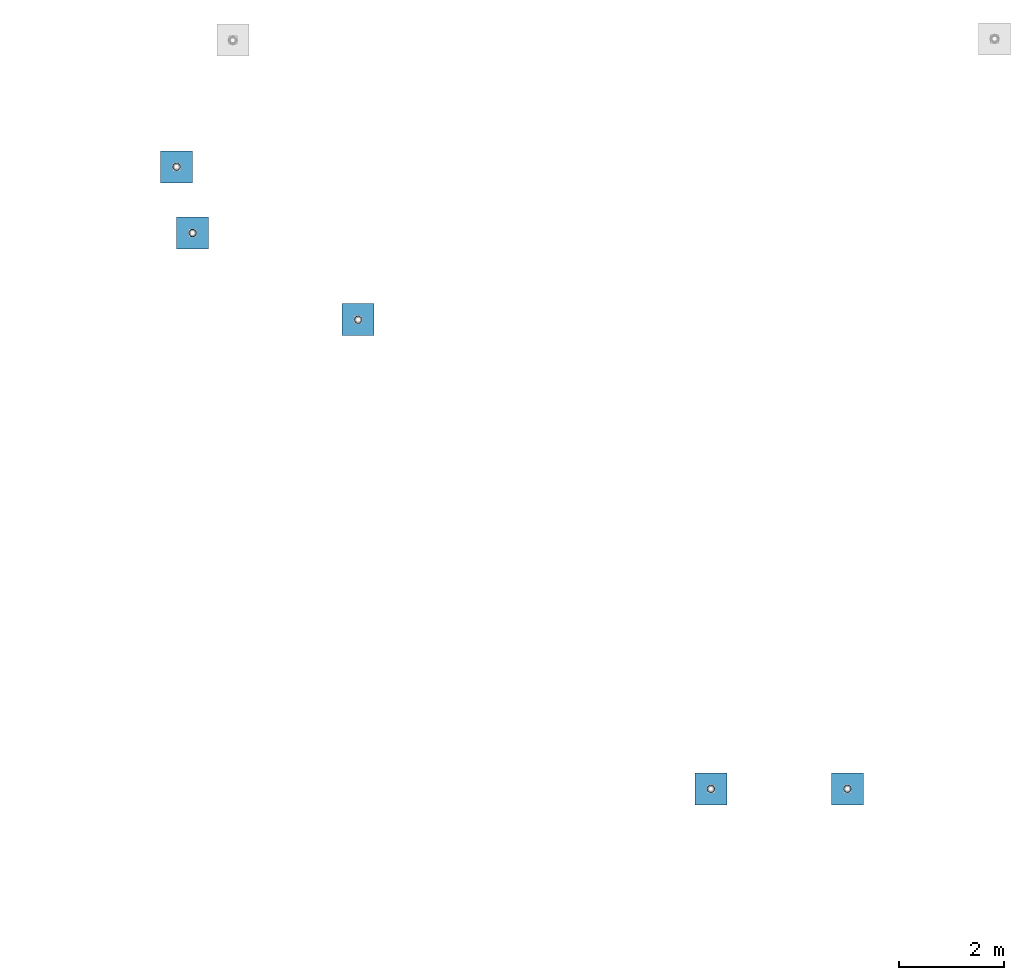
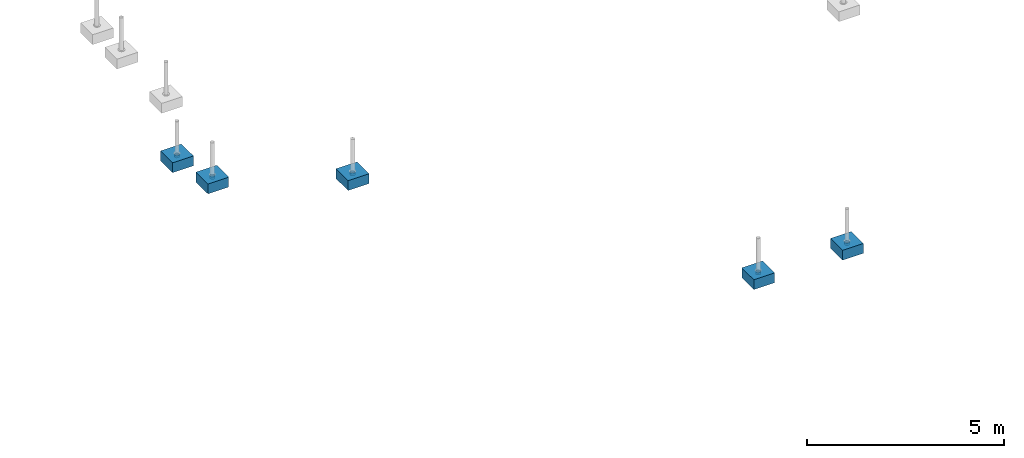
# One storey, part 1533 of 3843: 10 columns, 10 elements without a shape of their own.
"""IFC2X3 building model written with IfcOpenShell, lengths in millimetres."""

import ifcopenshell
import ifcopenshell.guid

model = None  # the IFC model being written
_history = None  # IfcOwnerHistory: only IFC2X3 demands one
_inside = {}  # id of a spatial element -> (the spatial element, [elements in it])
_under = {}  # id of a project, library or spatial element -> (it, [spatial elements below it])
_declared = {}  # id of a project -> (the project, [libraries it declares])
_typed = {}  # id of a type object -> (the type object, [elements of that type])
_made_of = {}  # id of a material, layer set ... -> (it, [elements and type objects made of it])


def new_model(schema):
    """Start an empty IFC model of exactly this schema.

    Asked for "IFC4X3", IfcOpenShell would pick the latest addendum, in which some entities
    have other attributes; the version numbers below select the first issue.
    IFC2X3 requires an IfcOwnerHistory on every rooted entity: one is made here for all.
    """
    global model, _history
    if schema == "IFC4X3":
        model = ifcopenshell.file(schema_version=(4, 3, 0, 0))
    else:
        model = ifcopenshell.file(schema=schema)
    _inside.clear()
    _under.clear()
    _declared.clear()
    _typed.clear()
    _made_of.clear()
    _history = None
    if model.schema == "IFC2X3":
        org = make("IfcOrganization", Name="unknown")
        user = make(
            "IfcPersonAndOrganization",
            ThePerson=make("IfcPerson", FamilyName="unknown"),
            TheOrganization=org,
        )
        app = make(
            "IfcApplication",
            ApplicationDeveloper=org,
            Version="unknown",
            ApplicationFullName="unknown",
            ApplicationIdentifier="unknown",
        )
        _history = make(
            "IfcOwnerHistory",
            OwningUser=user,
            OwningApplication=app,
            ChangeAction="ADDED",
            CreationDate=0,
        )
    return model


def make(cls, **values):
    """One entity of the class cls with the attributes given. An attribute that is None is left unset."""
    return model.create_entity(
        cls, **{name: value for name, value in values.items() if value is not None}
    )


def rooted(cls, **values):
    """An entity with a GlobalId (a new one), such as an element, a storey or a relation."""
    return make(cls, GlobalId=ifcopenshell.guid.new(), OwnerHistory=_history, **values)


def si_unit(unit_type, name, prefix=None):
    """IfcSIUnit, for example si_unit("LENGTHUNIT", "METRE", prefix="MILLI")."""
    return make("IfcSIUnit", UnitType=unit_type, Prefix=prefix, Name=name)


def assignment(units):
    """IfcUnitAssignment: the units of a project."""
    return None if units is None else make("IfcUnitAssignment", Units=units)


def point(xyz):
    """IfcCartesianPoint."""
    return None if xyz is None else make("IfcCartesianPoint", Coordinates=xyz)


def direction(xyz):
    """IfcDirection."""
    return None if xyz is None else make("IfcDirection", DirectionRatios=xyz)


def frame(location, z_axis=None, x_axis=None):
    """IfcAxis2Placement3D, a coordinate frame: its origin and axes. An axis left out is left unset."""
    return make(
        "IfcAxis2Placement3D",
        Location=point(location),
        Axis=direction(z_axis),
        RefDirection=direction(x_axis),
    )


def origin_with_axes():
    """The frame at (0, 0, 0) with the z axis (0, 0, 1) and the x axis (1, 0, 0) written out."""
    return frame((0.0, 0.0, 0.0), z_axis=(0.0, 0.0, 1.0), x_axis=(1.0, 0.0, 0.0))


def place(relative_to, where):
    """IfcLocalPlacement: puts the frame where relative to a parent placement (None: the world)."""
    return make(
        "IfcLocalPlacement", PlacementRelTo=relative_to, RelativePlacement=where
    )


def context(
    kind, dimensions, precision=None, world=None, true_north=None, identifier=None
):
    """IfcGeometricRepresentationContext, for example the 3D "Model" context."""
    return make(
        "IfcGeometricRepresentationContext",
        ContextIdentifier=identifier,
        ContextType=kind,
        CoordinateSpaceDimension=dimensions,
        Precision=precision,
        WorldCoordinateSystem=world,
        TrueNorth=true_north,
    )


def subcontext(parent, identifier, kind, view, scale=None):
    """IfcGeometricRepresentationSubContext, for example "Body" below "Model"."""
    return make(
        "IfcGeometricRepresentationSubContext",
        ContextIdentifier=identifier,
        ContextType=kind,
        ParentContext=parent,
        TargetScale=scale,
        TargetView=view,
    )


def project(units=None, contexts=None):
    """IfcProject with its units and contexts."""
    return rooted(
        "IfcProject",
        Name="project",
        RepresentationContexts=contexts,
        UnitsInContext=assignment(units),
    )


def spatial(cls, under=None, at=None, **own):
    """A site, building, storey or space (cls), placed at a placement, below another one or the project."""
    s = rooted(cls, ObjectPlacement=at, **own)
    if under is not None:
        _under.setdefault(under.id(), (under, []))[1].append(s)
    return s


def faces_of(points, faces, orient=None, outer=None):
    """IfcFace entities. A face is a list of loops; a loop is a list of indices into points, from 0.

    orient and outer hold one flag for each loop. By default every Orientation is true, the
    first loop of a face is its IfcFaceOuterBound and the others are IfcFaceBound.
    """
    made = []
    for i, loops in enumerate(faces):
        bounds = []
        for j, loop in enumerate(loops):
            is_outer = j == 0 if outer is None else outer[i][j]
            bounds.append(
                make(
                    "IfcFaceOuterBound" if is_outer else "IfcFaceBound",
                    Bound=make("IfcPolyLoop", Polygon=[points[k] for k in loop]),
                    Orientation=True if orient is None else orient[i][j],
                )
            )
        made.append(make("IfcFace", Bounds=bounds))
    return made


def faceted_brep(points, faces, orient=None, outer=None, voids=None):
    """IfcFacetedBrep: a solid bounded by flat faces; with voids (closed shells), ...WithVoids."""
    shared = [point(p) for p in points]
    hull = make("IfcClosedShell", CfsFaces=faces_of(shared, faces, orient, outer))
    if voids is None:
        return make("IfcFacetedBrep", Outer=hull)
    return make(
        "IfcFacetedBrepWithVoids",
        Outer=hull,
        Voids=[
            make(cls, CfsFaces=faces_of(shared, fs, o, b)) for cls, fs, o, b in voids
        ],
    )


def shape(context_of_items, identifier, shape_type, items):
    """IfcShapeRepresentation: the items that make up one representation, for example the "Body"."""
    return make(
        "IfcShapeRepresentation",
        ContextOfItems=context_of_items,
        RepresentationIdentifier=identifier,
        RepresentationType=shape_type,
        Items=items,
    )


def material(Name=None, Category=None):
    """IfcMaterial."""
    return make("IfcMaterial", Name=Name, Category=Category)


def made_of(thing, what):
    """Note that an element or type object is made of a material, layer set ...; save() writes the relation."""
    if what is not None:
        _made_of.setdefault(what.id(), (what, []))[1].append(thing)
    return thing


def type_object(cls, material=None, **own):
    """A type object (cls), such as IfcWallType, which elements share."""
    return made_of(rooted(cls, **own), material)


def element(
    cls,
    number,
    at=None,
    inside=None,
    cuts=None,
    type_object=None,
    material=None,
    context=None,
    identifier="Body",
    shape_type=None,
    held_by="IfcProductDefinitionShape",
    body=None,
    shapes=None,
    **own,
):
    """One element of the class cls, such as IfcWall. Its Tag is "e" and its number.

    at: its placement. inside: the storey or other place that contains it. cuts: it is an
    opening in that element (IfcRelVoidsElement). A single representation is given by context,
    identifier, shape_type and body (its items); several are given by shapes. held_by: the class
    of the entity that holds the representations. save() writes the other relations.
    """
    e = rooted(cls, Tag="e%d" % number, ObjectPlacement=at, **own)
    if body is not None:
        shapes = [shape(context, identifier, shape_type, body)]
    if shapes is not None:
        e.Representation = make(held_by, Representations=shapes)
    if inside is not None:
        _inside.setdefault(inside.id(), (inside, []))[1].append(e)
    if cuts is not None:
        rooted(
            "IfcRelVoidsElement", RelatingBuildingElement=cuts, RelatedOpeningElement=e
        )
    if type_object is not None:
        _typed.setdefault(type_object.id(), (type_object, []))[1].append(e)
    return made_of(e, material)


def aggregate(whole, parts):
    """IfcRelAggregates: a whole, such as a stair, and the parts it consists of."""
    return rooted("IfcRelAggregates", RelatingObject=whole, RelatedObjects=parts)


def save(model, path):
    """Write the relations noted so far, then the file.

    IfcRelAggregates (storeys below a building ...), IfcRelContainedInSpatialStructure (elements
    in a storey), IfcRelDefinesByType, IfcRelAssociatesMaterial and IfcRelDeclares: one each for
    every whole, place, type object, material and project.
    """
    for whole, parts in _under.values():
        aggregate(whole, parts)
    for where, things in _inside.values():
        rooted(
            "IfcRelContainedInSpatialStructure",
            RelatedElements=things,
            RelatingStructure=where,
        )
    for kind, things in _typed.values():
        rooted("IfcRelDefinesByType", RelatedObjects=things, RelatingType=kind)
    for what, things in _made_of.values():
        rooted("IfcRelAssociatesMaterial", RelatedObjects=things, RelatingMaterial=what)
    for by, libraries in _declared.values():
        rooted("IfcRelDeclares", RelatingContext=by, RelatedDefinitions=libraries)
    model.write(path)


model = new_model("IFC2X3")

# Units and contexts
model_context = context("Model", 3, precision=1e-05, world=origin_with_axes())
body_context = subcontext(model_context, "Body", "Model", "MODEL_VIEW")
ifc_project = project(units=[si_unit("LENGTHUNIT", "METRE", prefix="MILLI"), si_unit("AREAUNIT", "SQUARE_METRE"), si_unit("VOLUMEUNIT", "CUBIC_METRE"), si_unit("MASSUNIT", "GRAM", prefix="KILO"), si_unit("TIMEUNIT", "SECOND"), si_unit("PLANEANGLEUNIT", "RADIAN"), si_unit("SOLIDANGLEUNIT", "STERADIAN"), si_unit("THERMODYNAMICTEMPERATUREUNIT", "DEGREE_CELSIUS"), si_unit("LUMINOUSINTENSITYUNIT", "LUMEN")], contexts=[model_context])

# Site, building, storey
site_placement = place(None, origin_with_axes())
site = spatial("IfcSite", under=ifc_project, at=site_placement, CompositionType="ELEMENT")
building_placement = place(site_placement, origin_with_axes())
building = spatial("IfcBuilding", under=site, at=building_placement, Name="Undefined", CompositionType="ELEMENT")
storey_placement = place(building_placement, origin_with_axes())
storey = spatial("IfcBuildingStorey", under=building, at=storey_placement, Name="Undefined", CompositionType="ELEMENT", Elevation=0.0)

# Assembly, column
assembly_1_placement = place(storey_placement, origin_with_axes())
assembly_1 = element("IfcElementAssembly", 1, at=assembly_1_placement, inside=storey, Name="PLATE", AssemblyPlace="NOTDEFINED", PredefinedType="RIGID_FRAME")
ifc_material_1 = material()
column_type_1 = type_object("IfcColumnType", Name="PIPE5SCH40", PredefinedType="NOTDEFINED")
column_1_placement = place(assembly_1_placement, frame((-3692.61170980334, 71415.5314638615, 30378.4), z_axis=(-1.0, 0.0, 0.0), x_axis=(0.0, 0.0, 1.0)))
column_1 = element("IfcColumn", 2, at=column_1_placement, type_object=column_type_1, material=ifc_material_1, Name="PIPE_SLEEVE", ObjectType="PIPE5SCH40", context=body_context, shape_type="Brep", body=[
    faceted_brep([(0.0, -64.0587999999998, 0.0), (0.0, -60.9235391660477, 19.7952578392724), (76.2000000000007, -60.9235391660477, 19.7952578392724), (76.2000000000007, -64.0587999999998, 0.0), (0.0, -51.8246578392655, 37.6528179195593), (76.2000000000007, -51.8246578392655, 37.6528179195593), (0.0, -37.6528179195529, 51.8246578392718), (76.2000000000007, -37.6528179195529, 51.8246578392718), (0.0, -19.795257839266, 60.9235391660477), (76.2000000000007, -19.795257839266, 60.9235391660477), (0.0, 0.0, 64.0587999999989), (76.2000000000007, 0.0, 64.0587999999989), (0.0, 19.795257839266, 60.9235391660477), (76.2000000000007, 19.795257839266, 60.9235391660477), (0.0, 37.6528179195529, 51.8246578392718), (76.2000000000007, 37.6528179195529, 51.8246578392718), (0.0, 51.8246578392655, 37.6528179195593), (76.2000000000007, 51.8246578392655, 37.6528179195593), (0.0, 60.9235391660477, 19.7952578392724), (76.2000000000007, 60.9235391660477, 19.7952578392724), (0.0, 64.0587999999998, 0.0), (76.2000000000007, 64.0587999999998, 0.0), (0.0, 60.9235391660477, -19.7952578392724), (76.2000000000007, 60.9235391660477, -19.7952578392724), (0.0, 51.8246578392655, -37.6528179195593), (76.2000000000007, 51.8246578392655, -37.6528179195593), (0.0, 37.6528179195529, -51.8246578392718), (76.2000000000007, 37.6528179195529, -51.8246578392718), (0.0, 19.795257839266, -60.9235391660477), (76.2000000000007, 19.795257839266, -60.9235391660477), (0.0, 0.0, -64.0587999999989), (76.2000000000007, 0.0, -64.0587999999989), (0.0, -19.795257839266, -60.9235391660477), (76.2000000000007, -19.795257839266, -60.9235391660477), (0.0, -37.6528179195529, -51.8246578392718), (76.2000000000007, -37.6528179195529, -51.8246578392718), (0.0, -51.8246578392655, -37.6528179195593), (76.2000000000007, -51.8246578392655, -37.6528179195593), (0.0, -60.9235391660477, -19.7952578392724), (76.2000000000007, -60.9235391660477, -19.7952578392724), (0.0, -70.6120000000001, 0.0), (0.0, -67.1560027286332, -21.8203080068051), (76.2000000000007, -67.1560027286332, -21.8203080068051), (76.2000000000007, -70.6120000000001, 0.0), (0.0, -57.1263080068038, -41.5046922348702), (76.2000000000007, -57.1263080068038, -41.5046922348702), (0.0, -41.5046922348765, -57.126308006802), (76.2000000000007, -41.5046922348765, -57.126308006802), (0.0, -21.8203080068042, -67.1560027286323), (76.2000000000007, -21.8203080068042, -67.1560027286323), (0.0, 0.0, -70.6119999999937), (76.2000000000007, 0.0, -70.6119999999937), (0.0, 21.8203080068042, -67.1560027286323), (76.2000000000007, 21.8203080068042, -67.1560027286323), (0.0, 41.5046922348765, -57.126308006802), (76.2000000000007, 41.5046922348765, -57.126308006802), (0.0, 57.1263080068038, -41.5046922348702), (76.2000000000007, 57.1263080068038, -41.5046922348702), (0.0, 67.1560027286332, -21.8203080068051), (76.2000000000007, 67.1560027286332, -21.8203080068051), (0.0, 70.6120000000001, 0.0), (76.2000000000007, 70.6120000000001, 0.0), (0.0, 67.1560027286332, 21.8203080068051), (76.2000000000007, 67.1560027286332, 21.8203080068051), (0.0, 57.1263080068038, 41.5046922348702), (76.2000000000007, 57.1263080068038, 41.5046922348702), (0.0, 41.5046922348765, 57.126308006802), (76.2000000000007, 41.5046922348765, 57.126308006802), (0.0, 21.8203080068042, 67.1560027286323), (76.2000000000007, 21.8203080068042, 67.1560027286323), (0.0, 0.0, 70.6119999999937), (76.2000000000007, 0.0, 70.6119999999937), (0.0, -21.8203080068042, 67.1560027286323), (76.2000000000007, -21.8203080068042, 67.1560027286323), (0.0, -41.5046922348765, 57.126308006802), (76.2000000000007, -41.5046922348765, 57.126308006802), (0.0, -57.1263080068038, 41.5046922348702), (76.2000000000007, -57.1263080068038, 41.5046922348702), (0.0, -67.1560027286332, 21.8203080068051), (76.2000000000007, -67.1560027286332, 21.8203080068051)], [[[0, 1, 2, 3]], [[1, 4, 5, 2]], [[4, 6, 7, 5]], [[6, 8, 9, 7]], [[8, 10, 11, 9]], [[10, 12, 13, 11]], [[12, 14, 15, 13]], [[14, 16, 17, 15]], [[16, 18, 19, 17]], [[18, 20, 21, 19]], [[20, 22, 23, 21]], [[22, 24, 25, 23]], [[24, 26, 27, 25]], [[26, 28, 29, 27]], [[28, 30, 31, 29]], [[30, 32, 33, 31]], [[32, 34, 35, 33]], [[34, 36, 37, 35]], [[36, 38, 39, 37]], [[38, 0, 3, 39]], [[40, 41, 42, 43]], [[41, 44, 45, 42]], [[44, 46, 47, 45]], [[46, 48, 49, 47]], [[48, 50, 51, 49]], [[50, 52, 53, 51]], [[52, 54, 55, 53]], [[54, 56, 57, 55]], [[56, 58, 59, 57]], [[58, 60, 61, 59]], [[60, 62, 63, 61]], [[62, 64, 65, 63]], [[64, 66, 67, 65]], [[66, 68, 69, 67]], [[68, 70, 71, 69]], [[70, 72, 73, 71]], [[72, 74, 75, 73]], [[74, 76, 77, 75]], [[76, 78, 79, 77]], [[78, 40, 43, 79]], [[45, 47, 49, 51, 53, 55, 57, 59, 61, 63, 65, 67, 69, 71, 73, 75, 77, 79, 43, 42], [5, 7, 9, 11, 13, 15, 17, 19, 21, 23, 25, 27, 29, 31, 33, 35, 37, 39, 3, 2]], [[78, 76, 74, 72, 70, 68, 66, 64, 62, 60, 58, 56, 54, 52, 50, 48, 46, 44, 41, 40], [38, 36, 34, 32, 30, 28, 26, 24, 22, 20, 18, 16, 14, 12, 10, 8, 6, 4, 1, 0]]]),
])
aggregate(assembly_1, [column_1])

assembly_2_placement = place(storey_placement, origin_with_axes())
assembly_2 = element("IfcElementAssembly", 3, at=assembly_2_placement, inside=storey, Name="PLATE", AssemblyPlace="NOTDEFINED", PredefinedType="RIGID_FRAME")
column_2_placement = place(assembly_2_placement, frame((-6292.19438192249, 71414.9058535099, 30378.4), z_axis=(-1.0, 0.0, 0.0), x_axis=(0.0, 0.0, 1.0)))
column_2 = element("IfcColumn", 4, at=column_2_placement, type_object=column_type_1, material=ifc_material_1, Name="PIPE_SLEEVE", ObjectType="PIPE5SCH40", context=body_context, shape_type="Brep", body=[
    faceted_brep([(0.0, -64.0587999999998, 0.0), (0.0, -60.9235391660477, 19.7952578392724), (76.2000000000007, -60.9235391660477, 19.7952578392724), (76.2000000000007, -64.0587999999998, 0.0), (0.0, -51.8246578392655, 37.6528179195593), (76.2000000000007, -51.8246578392655, 37.6528179195593), (0.0, -37.6528179195529, 51.8246578392718), (76.2000000000007, -37.6528179195529, 51.8246578392718), (0.0, -19.795257839266, 60.9235391660477), (76.2000000000007, -19.795257839266, 60.9235391660477), (0.0, 0.0, 64.0587999999989), (76.2000000000007, 0.0, 64.0587999999989), (0.0, 19.795257839266, 60.9235391660477), (76.2000000000007, 19.795257839266, 60.9235391660477), (0.0, 37.6528179195529, 51.8246578392718), (76.2000000000007, 37.6528179195529, 51.8246578392718), (0.0, 51.8246578392655, 37.6528179195593), (76.2000000000007, 51.8246578392655, 37.6528179195593), (0.0, 60.9235391660477, 19.7952578392724), (76.2000000000007, 60.9235391660477, 19.7952578392724), (0.0, 64.0587999999998, 0.0), (76.2000000000007, 64.0587999999998, 0.0), (0.0, 60.9235391660477, -19.7952578392724), (76.2000000000007, 60.9235391660477, -19.7952578392724), (0.0, 51.8246578392655, -37.6528179195593), (76.2000000000007, 51.8246578392655, -37.6528179195593), (0.0, 37.6528179195529, -51.8246578392718), (76.2000000000007, 37.6528179195529, -51.8246578392718), (0.0, 19.795257839266, -60.9235391660477), (76.2000000000007, 19.795257839266, -60.9235391660477), (0.0, 0.0, -64.0587999999989), (76.2000000000007, 0.0, -64.0587999999989), (0.0, -19.795257839266, -60.9235391660477), (76.2000000000007, -19.795257839266, -60.9235391660477), (0.0, -37.6528179195529, -51.8246578392718), (76.2000000000007, -37.6528179195529, -51.8246578392718), (0.0, -51.8246578392655, -37.6528179195593), (76.2000000000007, -51.8246578392655, -37.6528179195593), (0.0, -60.9235391660477, -19.7952578392724), (76.2000000000007, -60.9235391660477, -19.7952578392724), (0.0, -70.6120000000001, 0.0), (0.0, -67.1560027286332, -21.8203080068051), (76.2000000000007, -67.1560027286332, -21.8203080068051), (76.2000000000007, -70.6120000000001, 0.0), (0.0, -57.1263080068038, -41.5046922348702), (76.2000000000007, -57.1263080068038, -41.5046922348702), (0.0, -41.5046922348765, -57.126308006802), (76.2000000000007, -41.5046922348765, -57.126308006802), (0.0, -21.8203080068042, -67.1560027286323), (76.2000000000007, -21.8203080068042, -67.1560027286323), (0.0, 0.0, -70.6119999999937), (76.2000000000007, 0.0, -70.6119999999937), (0.0, 21.8203080068042, -67.1560027286323), (76.2000000000007, 21.8203080068042, -67.1560027286323), (0.0, 41.5046922348765, -57.126308006802), (76.2000000000007, 41.5046922348765, -57.126308006802), (0.0, 57.1263080068038, -41.5046922348702), (76.2000000000007, 57.1263080068038, -41.5046922348702), (0.0, 67.1560027286332, -21.8203080068051), (76.2000000000007, 67.1560027286332, -21.8203080068051), (0.0, 70.6120000000001, 0.0), (76.2000000000007, 70.6120000000001, 0.0), (0.0, 67.1560027286332, 21.8203080068051), (76.2000000000007, 67.1560027286332, 21.8203080068051), (0.0, 57.1263080068038, 41.5046922348702), (76.2000000000007, 57.1263080068038, 41.5046922348702), (0.0, 41.5046922348765, 57.126308006802), (76.2000000000007, 41.5046922348765, 57.126308006802), (0.0, 21.8203080068042, 67.1560027286323), (76.2000000000007, 21.8203080068042, 67.1560027286323), (0.0, 0.0, 70.6119999999937), (76.2000000000007, 0.0, 70.6119999999937), (0.0, -21.8203080068042, 67.1560027286323), (76.2000000000007, -21.8203080068042, 67.1560027286323), (0.0, -41.5046922348765, 57.126308006802), (76.2000000000007, -41.5046922348765, 57.126308006802), (0.0, -57.1263080068038, 41.5046922348702), (76.2000000000007, -57.1263080068038, 41.5046922348702), (0.0, -67.1560027286332, 21.8203080068051), (76.2000000000007, -67.1560027286332, 21.8203080068051)], [[[0, 1, 2, 3]], [[1, 4, 5, 2]], [[4, 6, 7, 5]], [[6, 8, 9, 7]], [[8, 10, 11, 9]], [[10, 12, 13, 11]], [[12, 14, 15, 13]], [[14, 16, 17, 15]], [[16, 18, 19, 17]], [[18, 20, 21, 19]], [[20, 22, 23, 21]], [[22, 24, 25, 23]], [[24, 26, 27, 25]], [[26, 28, 29, 27]], [[28, 30, 31, 29]], [[30, 32, 33, 31]], [[32, 34, 35, 33]], [[34, 36, 37, 35]], [[36, 38, 39, 37]], [[38, 0, 3, 39]], [[40, 41, 42, 43]], [[41, 44, 45, 42]], [[44, 46, 47, 45]], [[46, 48, 49, 47]], [[48, 50, 51, 49]], [[50, 52, 53, 51]], [[52, 54, 55, 53]], [[54, 56, 57, 55]], [[56, 58, 59, 57]], [[58, 60, 61, 59]], [[60, 62, 63, 61]], [[62, 64, 65, 63]], [[64, 66, 67, 65]], [[66, 68, 69, 67]], [[68, 70, 71, 69]], [[70, 72, 73, 71]], [[72, 74, 75, 73]], [[74, 76, 77, 75]], [[76, 78, 79, 77]], [[78, 40, 43, 79]], [[45, 47, 49, 51, 53, 55, 57, 59, 61, 63, 65, 67, 69, 71, 73, 75, 77, 79, 43, 42], [5, 7, 9, 11, 13, 15, 17, 19, 21, 23, 25, 27, 29, 31, 33, 35, 37, 39, 3, 2]], [[78, 76, 74, 72, 70, 68, 66, 64, 62, 60, 58, 56, 54, 52, 50, 48, 46, 44, 41, 40], [38, 36, 34, 32, 30, 28, 26, 24, 22, 20, 18, 16, 14, 12, 10, 8, 6, 4, 1, 0]]]),
])
aggregate(assembly_2, [column_2])

assembly_3_placement = place(storey_placement, origin_with_axes())
assembly_3 = element("IfcElementAssembly", 5, at=assembly_3_placement, inside=storey, Name="PLATE", AssemblyPlace="NOTDEFINED", PredefinedType="RIGID_FRAME")
column_3_placement = place(assembly_3_placement, frame((-13009.9315797985, 80350.2009584904, 30378.4), z_axis=(-1.0, 0.0, 0.0), x_axis=(0.0, 0.0, 1.0)))
column_3 = element("IfcColumn", 6, at=column_3_placement, type_object=column_type_1, material=ifc_material_1, Name="PIPE_SLEEVE", ObjectType="PIPE5SCH40", context=body_context, shape_type="Brep", body=[
    faceted_brep([(0.0, -64.0587999999998, 0.0), (0.0, -60.9235391660477, 19.7952578392724), (76.2000000000007, -60.9235391660477, 19.7952578392724), (76.2000000000007, -64.0587999999998, 0.0), (0.0, -51.8246578392655, 37.6528179195593), (76.2000000000007, -51.8246578392655, 37.6528179195593), (0.0, -37.6528179195529, 51.8246578392718), (76.2000000000007, -37.6528179195529, 51.8246578392718), (0.0, -19.795257839266, 60.9235391660477), (76.2000000000007, -19.795257839266, 60.9235391660477), (0.0, 0.0, 64.0587999999989), (76.2000000000007, 0.0, 64.0587999999989), (0.0, 19.795257839266, 60.9235391660477), (76.2000000000007, 19.795257839266, 60.9235391660477), (0.0, 37.6528179195529, 51.8246578392718), (76.2000000000007, 37.6528179195529, 51.8246578392718), (0.0, 51.8246578392655, 37.6528179195593), (76.2000000000007, 51.8246578392655, 37.6528179195593), (0.0, 60.9235391660477, 19.7952578392724), (76.2000000000007, 60.9235391660477, 19.7952578392724), (0.0, 64.0587999999998, 0.0), (76.2000000000007, 64.0587999999998, 0.0), (0.0, 60.9235391660477, -19.7952578392724), (76.2000000000007, 60.9235391660477, -19.7952578392724), (0.0, 51.8246578392655, -37.6528179195593), (76.2000000000007, 51.8246578392655, -37.6528179195593), (0.0, 37.6528179195529, -51.8246578392718), (76.2000000000007, 37.6528179195529, -51.8246578392718), (0.0, 19.795257839266, -60.9235391660477), (76.2000000000007, 19.795257839266, -60.9235391660477), (0.0, 0.0, -64.0587999999989), (76.2000000000007, 0.0, -64.0587999999989), (0.0, -19.795257839266, -60.9235391660477), (76.2000000000007, -19.795257839266, -60.9235391660477), (0.0, -37.6528179195529, -51.8246578392718), (76.2000000000007, -37.6528179195529, -51.8246578392718), (0.0, -51.8246578392655, -37.6528179195593), (76.2000000000007, -51.8246578392655, -37.6528179195593), (0.0, -60.9235391660477, -19.7952578392724), (76.2000000000007, -60.9235391660477, -19.7952578392724), (0.0, -70.6120000000001, 0.0), (0.0, -67.1560027286332, -21.8203080068051), (76.2000000000007, -67.1560027286332, -21.8203080068051), (76.2000000000007, -70.6120000000001, 0.0), (0.0, -57.1263080068038, -41.5046922348702), (76.2000000000007, -57.1263080068038, -41.5046922348702), (0.0, -41.5046922348765, -57.126308006802), (76.2000000000007, -41.5046922348765, -57.126308006802), (0.0, -21.8203080068042, -67.1560027286323), (76.2000000000007, -21.8203080068042, -67.1560027286323), (0.0, 0.0, -70.6119999999937), (76.2000000000007, 0.0, -70.6119999999937), (0.0, 21.8203080068042, -67.1560027286323), (76.2000000000007, 21.8203080068042, -67.1560027286323), (0.0, 41.5046922348765, -57.126308006802), (76.2000000000007, 41.5046922348765, -57.126308006802), (0.0, 57.1263080068038, -41.5046922348702), (76.2000000000007, 57.1263080068038, -41.5046922348702), (0.0, 67.1560027286332, -21.8203080068051), (76.2000000000007, 67.1560027286332, -21.8203080068051), (0.0, 70.6120000000001, 0.0), (76.2000000000007, 70.6120000000001, 0.0), (0.0, 67.1560027286332, 21.8203080068051), (76.2000000000007, 67.1560027286332, 21.8203080068051), (0.0, 57.1263080068038, 41.5046922348702), (76.2000000000007, 57.1263080068038, 41.5046922348702), (0.0, 41.5046922348765, 57.126308006802), (76.2000000000007, 41.5046922348765, 57.126308006802), (0.0, 21.8203080068042, 67.1560027286323), (76.2000000000007, 21.8203080068042, 67.1560027286323), (0.0, 0.0, 70.6119999999937), (76.2000000000007, 0.0, 70.6119999999937), (0.0, -21.8203080068042, 67.1560027286323), (76.2000000000007, -21.8203080068042, 67.1560027286323), (0.0, -41.5046922348765, 57.126308006802), (76.2000000000007, -41.5046922348765, 57.126308006802), (0.0, -57.1263080068038, 41.5046922348702), (76.2000000000007, -57.1263080068038, 41.5046922348702), (0.0, -67.1560027286332, 21.8203080068051), (76.2000000000007, -67.1560027286332, 21.8203080068051)], [[[0, 1, 2, 3]], [[1, 4, 5, 2]], [[4, 6, 7, 5]], [[6, 8, 9, 7]], [[8, 10, 11, 9]], [[10, 12, 13, 11]], [[12, 14, 15, 13]], [[14, 16, 17, 15]], [[16, 18, 19, 17]], [[18, 20, 21, 19]], [[20, 22, 23, 21]], [[22, 24, 25, 23]], [[24, 26, 27, 25]], [[26, 28, 29, 27]], [[28, 30, 31, 29]], [[30, 32, 33, 31]], [[32, 34, 35, 33]], [[34, 36, 37, 35]], [[36, 38, 39, 37]], [[38, 0, 3, 39]], [[40, 41, 42, 43]], [[41, 44, 45, 42]], [[44, 46, 47, 45]], [[46, 48, 49, 47]], [[48, 50, 51, 49]], [[50, 52, 53, 51]], [[52, 54, 55, 53]], [[54, 56, 57, 55]], [[56, 58, 59, 57]], [[58, 60, 61, 59]], [[60, 62, 63, 61]], [[62, 64, 65, 63]], [[64, 66, 67, 65]], [[66, 68, 69, 67]], [[68, 70, 71, 69]], [[70, 72, 73, 71]], [[72, 74, 75, 73]], [[74, 76, 77, 75]], [[76, 78, 79, 77]], [[78, 40, 43, 79]], [[45, 47, 49, 51, 53, 55, 57, 59, 61, 63, 65, 67, 69, 71, 73, 75, 77, 79, 43, 42], [5, 7, 9, 11, 13, 15, 17, 19, 21, 23, 25, 27, 29, 31, 33, 35, 37, 39, 3, 2]], [[78, 76, 74, 72, 70, 68, 66, 64, 62, 60, 58, 56, 54, 52, 50, 48, 46, 44, 41, 40], [38, 36, 34, 32, 30, 28, 26, 24, 22, 20, 18, 16, 14, 12, 10, 8, 6, 4, 1, 0]]]),
])
aggregate(assembly_3, [column_3])

assembly_4_placement = place(storey_placement, origin_with_axes())
assembly_4 = element("IfcElementAssembly", 7, at=assembly_4_placement, inside=storey, Name="PLATE", AssemblyPlace="NOTDEFINED", PredefinedType="RIGID_FRAME")
column_4_placement = place(assembly_4_placement, frame((-16161.9587099254, 81999.8381807804, 30378.4), z_axis=(-1.0, 0.0, 0.0), x_axis=(0.0, 0.0, 1.0)))
column_4 = element("IfcColumn", 8, at=column_4_placement, type_object=column_type_1, material=ifc_material_1, Name="PIPE_SLEEVE", ObjectType="PIPE5SCH40", context=body_context, shape_type="Brep", body=[
    faceted_brep([(0.0, -64.0587999999998, 0.0), (0.0, -60.9235391660477, 19.7952578392724), (76.2000000000007, -60.9235391660477, 19.7952578392724), (76.2000000000007, -64.0587999999998, 0.0), (0.0, -51.8246578392655, 37.6528179195593), (76.2000000000007, -51.8246578392655, 37.6528179195593), (0.0, -37.6528179195529, 51.8246578392718), (76.2000000000007, -37.6528179195529, 51.8246578392718), (0.0, -19.795257839266, 60.9235391660477), (76.2000000000007, -19.795257839266, 60.9235391660477), (0.0, 0.0, 64.0587999999989), (76.2000000000007, 0.0, 64.0587999999989), (0.0, 19.795257839266, 60.9235391660477), (76.2000000000007, 19.795257839266, 60.9235391660477), (0.0, 37.6528179195529, 51.8246578392718), (76.2000000000007, 37.6528179195529, 51.8246578392718), (0.0, 51.8246578392655, 37.6528179195593), (76.2000000000007, 51.8246578392655, 37.6528179195593), (0.0, 60.9235391660477, 19.7952578392724), (76.2000000000007, 60.9235391660477, 19.7952578392724), (0.0, 64.0587999999998, 0.0), (76.2000000000007, 64.0587999999998, 0.0), (0.0, 60.9235391660477, -19.7952578392724), (76.2000000000007, 60.9235391660477, -19.7952578392724), (0.0, 51.8246578392655, -37.6528179195593), (76.2000000000007, 51.8246578392655, -37.6528179195593), (0.0, 37.6528179195529, -51.8246578392718), (76.2000000000007, 37.6528179195529, -51.8246578392718), (0.0, 19.795257839266, -60.9235391660477), (76.2000000000007, 19.795257839266, -60.9235391660477), (0.0, 0.0, -64.0587999999989), (76.2000000000007, 0.0, -64.0587999999989), (0.0, -19.795257839266, -60.9235391660477), (76.2000000000007, -19.795257839266, -60.9235391660477), (0.0, -37.6528179195529, -51.8246578392718), (76.2000000000007, -37.6528179195529, -51.8246578392718), (0.0, -51.8246578392655, -37.6528179195593), (76.2000000000007, -51.8246578392655, -37.6528179195593), (0.0, -60.9235391660477, -19.7952578392724), (76.2000000000007, -60.9235391660477, -19.7952578392724), (0.0, -70.6120000000001, 0.0), (0.0, -67.1560027286332, -21.8203080068051), (76.2000000000007, -67.1560027286332, -21.8203080068051), (76.2000000000007, -70.6120000000001, 0.0), (0.0, -57.1263080068038, -41.5046922348702), (76.2000000000007, -57.1263080068038, -41.5046922348702), (0.0, -41.5046922348765, -57.126308006802), (76.2000000000007, -41.5046922348765, -57.126308006802), (0.0, -21.8203080068042, -67.1560027286323), (76.2000000000007, -21.8203080068042, -67.1560027286323), (0.0, 0.0, -70.6119999999937), (76.2000000000007, 0.0, -70.6119999999937), (0.0, 21.8203080068042, -67.1560027286323), (76.2000000000007, 21.8203080068042, -67.1560027286323), (0.0, 41.5046922348765, -57.126308006802), (76.2000000000007, 41.5046922348765, -57.126308006802), (0.0, 57.1263080068038, -41.5046922348702), (76.2000000000007, 57.1263080068038, -41.5046922348702), (0.0, 67.1560027286332, -21.8203080068051), (76.2000000000007, 67.1560027286332, -21.8203080068051), (0.0, 70.6120000000001, 0.0), (76.2000000000007, 70.6120000000001, 0.0), (0.0, 67.1560027286332, 21.8203080068051), (76.2000000000007, 67.1560027286332, 21.8203080068051), (0.0, 57.1263080068038, 41.5046922348702), (76.2000000000007, 57.1263080068038, 41.5046922348702), (0.0, 41.5046922348765, 57.126308006802), (76.2000000000007, 41.5046922348765, 57.126308006802), (0.0, 21.8203080068042, 67.1560027286323), (76.2000000000007, 21.8203080068042, 67.1560027286323), (0.0, 0.0, 70.6119999999937), (76.2000000000007, 0.0, 70.6119999999937), (0.0, -21.8203080068042, 67.1560027286323), (76.2000000000007, -21.8203080068042, 67.1560027286323), (0.0, -41.5046922348765, 57.126308006802), (76.2000000000007, -41.5046922348765, 57.126308006802), (0.0, -57.1263080068038, 41.5046922348702), (76.2000000000007, -57.1263080068038, 41.5046922348702), (0.0, -67.1560027286332, 21.8203080068051), (76.2000000000007, -67.1560027286332, 21.8203080068051)], [[[0, 1, 2, 3]], [[1, 4, 5, 2]], [[4, 6, 7, 5]], [[6, 8, 9, 7]], [[8, 10, 11, 9]], [[10, 12, 13, 11]], [[12, 14, 15, 13]], [[14, 16, 17, 15]], [[16, 18, 19, 17]], [[18, 20, 21, 19]], [[20, 22, 23, 21]], [[22, 24, 25, 23]], [[24, 26, 27, 25]], [[26, 28, 29, 27]], [[28, 30, 31, 29]], [[30, 32, 33, 31]], [[32, 34, 35, 33]], [[34, 36, 37, 35]], [[36, 38, 39, 37]], [[38, 0, 3, 39]], [[40, 41, 42, 43]], [[41, 44, 45, 42]], [[44, 46, 47, 45]], [[46, 48, 49, 47]], [[48, 50, 51, 49]], [[50, 52, 53, 51]], [[52, 54, 55, 53]], [[54, 56, 57, 55]], [[56, 58, 59, 57]], [[58, 60, 61, 59]], [[60, 62, 63, 61]], [[62, 64, 65, 63]], [[64, 66, 67, 65]], [[66, 68, 69, 67]], [[68, 70, 71, 69]], [[70, 72, 73, 71]], [[72, 74, 75, 73]], [[74, 76, 77, 75]], [[76, 78, 79, 77]], [[78, 40, 43, 79]], [[45, 47, 49, 51, 53, 55, 57, 59, 61, 63, 65, 67, 69, 71, 73, 75, 77, 79, 43, 42], [5, 7, 9, 11, 13, 15, 17, 19, 21, 23, 25, 27, 29, 31, 33, 35, 37, 39, 3, 2]], [[78, 76, 74, 72, 70, 68, 66, 64, 62, 60, 58, 56, 54, 52, 50, 48, 46, 44, 41, 40], [38, 36, 34, 32, 30, 28, 26, 24, 22, 20, 18, 16, 14, 12, 10, 8, 6, 4, 1, 0]]]),
])
aggregate(assembly_4, [column_4])

assembly_5_placement = place(storey_placement, origin_with_axes())
assembly_5 = element("IfcElementAssembly", 9, at=assembly_5_placement, inside=storey, Name="PLATE", AssemblyPlace="NOTDEFINED", PredefinedType="RIGID_FRAME")
column_5_placement = place(assembly_5_placement, frame((-16467.6075136364, 83260.6490328312, 30378.4), z_axis=(-1.0, 0.0, 0.0), x_axis=(0.0, 0.0, 1.0)))
column_5 = element("IfcColumn", 10, at=column_5_placement, type_object=column_type_1, material=ifc_material_1, Name="PIPE_SLEEVE", ObjectType="PIPE5SCH40", context=body_context, shape_type="Brep", body=[
    faceted_brep([(0.0, -64.0587999999998, 0.0), (0.0, -60.9235391660477, 19.7952578392724), (76.2000000000007, -60.9235391660477, 19.7952578392724), (76.2000000000007, -64.0587999999998, 0.0), (0.0, -51.8246578392655, 37.6528179195593), (76.2000000000007, -51.8246578392655, 37.6528179195593), (0.0, -37.6528179195529, 51.8246578392718), (76.2000000000007, -37.6528179195529, 51.8246578392718), (0.0, -19.795257839266, 60.9235391660477), (76.2000000000007, -19.795257839266, 60.9235391660477), (0.0, 0.0, 64.0587999999989), (76.2000000000007, 0.0, 64.0587999999989), (0.0, 19.795257839266, 60.9235391660477), (76.2000000000007, 19.795257839266, 60.9235391660477), (0.0, 37.6528179195529, 51.8246578392718), (76.2000000000007, 37.6528179195529, 51.8246578392718), (0.0, 51.8246578392655, 37.6528179195593), (76.2000000000007, 51.8246578392655, 37.6528179195593), (0.0, 60.9235391660477, 19.7952578392724), (76.2000000000007, 60.9235391660477, 19.7952578392724), (0.0, 64.0587999999998, 0.0), (76.2000000000007, 64.0587999999998, 0.0), (0.0, 60.9235391660477, -19.7952578392724), (76.2000000000007, 60.9235391660477, -19.7952578392724), (0.0, 51.8246578392655, -37.6528179195593), (76.2000000000007, 51.8246578392655, -37.6528179195593), (0.0, 37.6528179195529, -51.8246578392718), (76.2000000000007, 37.6528179195529, -51.8246578392718), (0.0, 19.795257839266, -60.9235391660477), (76.2000000000007, 19.795257839266, -60.9235391660477), (0.0, 0.0, -64.0587999999989), (76.2000000000007, 0.0, -64.0587999999989), (0.0, -19.795257839266, -60.9235391660477), (76.2000000000007, -19.795257839266, -60.9235391660477), (0.0, -37.6528179195529, -51.8246578392718), (76.2000000000007, -37.6528179195529, -51.8246578392718), (0.0, -51.8246578392655, -37.6528179195593), (76.2000000000007, -51.8246578392655, -37.6528179195593), (0.0, -60.9235391660477, -19.7952578392724), (76.2000000000007, -60.9235391660477, -19.7952578392724), (0.0, -70.6120000000001, 0.0), (0.0, -67.1560027286332, -21.8203080068051), (76.2000000000007, -67.1560027286332, -21.8203080068051), (76.2000000000007, -70.6120000000001, 0.0), (0.0, -57.1263080068038, -41.5046922348702), (76.2000000000007, -57.1263080068038, -41.5046922348702), (0.0, -41.5046922348765, -57.126308006802), (76.2000000000007, -41.5046922348765, -57.126308006802), (0.0, -21.8203080068042, -67.1560027286323), (76.2000000000007, -21.8203080068042, -67.1560027286323), (0.0, 0.0, -70.6119999999937), (76.2000000000007, 0.0, -70.6119999999937), (0.0, 21.8203080068042, -67.1560027286323), (76.2000000000007, 21.8203080068042, -67.1560027286323), (0.0, 41.5046922348765, -57.126308006802), (76.2000000000007, 41.5046922348765, -57.126308006802), (0.0, 57.1263080068038, -41.5046922348702), (76.2000000000007, 57.1263080068038, -41.5046922348702), (0.0, 67.1560027286332, -21.8203080068051), (76.2000000000007, 67.1560027286332, -21.8203080068051), (0.0, 70.6120000000001, 0.0), (76.2000000000007, 70.6120000000001, 0.0), (0.0, 67.1560027286332, 21.8203080068051), (76.2000000000007, 67.1560027286332, 21.8203080068051), (0.0, 57.1263080068038, 41.5046922348702), (76.2000000000007, 57.1263080068038, 41.5046922348702), (0.0, 41.5046922348765, 57.126308006802), (76.2000000000007, 41.5046922348765, 57.126308006802), (0.0, 21.8203080068042, 67.1560027286323), (76.2000000000007, 21.8203080068042, 67.1560027286323), (0.0, 0.0, 70.6119999999937), (76.2000000000007, 0.0, 70.6119999999937), (0.0, -21.8203080068042, 67.1560027286323), (76.2000000000007, -21.8203080068042, 67.1560027286323), (0.0, -41.5046922348765, 57.126308006802), (76.2000000000007, -41.5046922348765, 57.126308006802), (0.0, -57.1263080068038, 41.5046922348702), (76.2000000000007, -57.1263080068038, 41.5046922348702), (0.0, -67.1560027286332, 21.8203080068051), (76.2000000000007, -67.1560027286332, 21.8203080068051)], [[[0, 1, 2, 3]], [[1, 4, 5, 2]], [[4, 6, 7, 5]], [[6, 8, 9, 7]], [[8, 10, 11, 9]], [[10, 12, 13, 11]], [[12, 14, 15, 13]], [[14, 16, 17, 15]], [[16, 18, 19, 17]], [[18, 20, 21, 19]], [[20, 22, 23, 21]], [[22, 24, 25, 23]], [[24, 26, 27, 25]], [[26, 28, 29, 27]], [[28, 30, 31, 29]], [[30, 32, 33, 31]], [[32, 34, 35, 33]], [[34, 36, 37, 35]], [[36, 38, 39, 37]], [[38, 0, 3, 39]], [[40, 41, 42, 43]], [[41, 44, 45, 42]], [[44, 46, 47, 45]], [[46, 48, 49, 47]], [[48, 50, 51, 49]], [[50, 52, 53, 51]], [[52, 54, 55, 53]], [[54, 56, 57, 55]], [[56, 58, 59, 57]], [[58, 60, 61, 59]], [[60, 62, 63, 61]], [[62, 64, 65, 63]], [[64, 66, 67, 65]], [[66, 68, 69, 67]], [[68, 70, 71, 69]], [[70, 72, 73, 71]], [[72, 74, 75, 73]], [[74, 76, 77, 75]], [[76, 78, 79, 77]], [[78, 40, 43, 79]], [[45, 47, 49, 51, 53, 55, 57, 59, 61, 63, 65, 67, 69, 71, 73, 75, 77, 79, 43, 42], [5, 7, 9, 11, 13, 15, 17, 19, 21, 23, 25, 27, 29, 31, 33, 35, 37, 39, 3, 2]], [[78, 76, 74, 72, 70, 68, 66, 64, 62, 60, 58, 56, 54, 52, 50, 48, 46, 44, 41, 40], [38, 36, 34, 32, 30, 28, 26, 24, 22, 20, 18, 16, 14, 12, 10, 8, 6, 4, 1, 0]]]),
])
aggregate(assembly_5, [column_5])

assembly_6_placement = place(storey_placement, origin_with_axes())
assembly_6 = element("IfcElementAssembly", 11, at=assembly_6_placement, inside=storey, Name="CONC_COL.", AssemblyPlace="NOTDEFINED", PredefinedType="REINFORCEMENT_UNIT")
ifc_material_2 = material(Name="CONCRETE/3000")
column_type_2 = type_object("IfcColumnType", PredefinedType="NOTDEFINED")
column_6_placement = place(assembly_6_placement, frame((-3692.61170980334, 71415.5314638615, 30175.2), z_axis=(-1.0, 0.0, 0.0), x_axis=(0.0, 0.0, 1.0)))
column_6 = element("IfcColumn", 12, at=column_6_placement, type_object=column_type_2, material=ifc_material_2, Name="CONC_COL.", context=body_context, shape_type="Brep", body=[
    faceted_brep([(0.0, 304.8, -304.800000000003), (0.0, 304.8, 304.800000000003), (304.799999999999, 304.8, 304.800000000003), (304.799999999999, 304.8, -304.800000000003), (0.0, -304.8, 304.800000000003), (304.799999999999, -304.8, 304.800000000003), (0.0, -304.8, -304.800000000003), (304.799999999999, -304.8, -304.800000000003)], [[[0, 1, 2, 3]], [[1, 4, 5, 2]], [[4, 6, 7, 5]], [[6, 0, 3, 7]], [[5, 7, 3, 2]], [[6, 4, 1, 0]]]),
])
aggregate(assembly_6, [column_6])

assembly_7_placement = place(storey_placement, origin_with_axes())
assembly_7 = element("IfcElementAssembly", 13, at=assembly_7_placement, inside=storey, Name="CONC_COL.", AssemblyPlace="NOTDEFINED", PredefinedType="REINFORCEMENT_UNIT")
column_7_placement = place(assembly_7_placement, frame((-6292.19438192249, 71414.9058535099, 30175.2), z_axis=(-1.0, 0.0, 0.0), x_axis=(0.0, 0.0, 1.0)))
column_7 = element("IfcColumn", 14, at=column_7_placement, type_object=column_type_2, material=ifc_material_2, Name="CONC_COL.", context=body_context, shape_type="Brep", body=[
    faceted_brep([(0.0, 304.8, -304.800000000003), (0.0, 304.8, 304.800000000003), (304.799999999999, 304.8, 304.800000000003), (304.799999999999, 304.8, -304.800000000003), (0.0, -304.8, 304.800000000003), (304.799999999999, -304.8, 304.800000000003), (0.0, -304.8, -304.800000000003), (304.799999999999, -304.8, -304.800000000003)], [[[0, 1, 2, 3]], [[1, 4, 5, 2]], [[4, 6, 7, 5]], [[6, 0, 3, 7]], [[5, 7, 3, 2]], [[6, 4, 1, 0]]]),
])
aggregate(assembly_7, [column_7])

assembly_8_placement = place(storey_placement, origin_with_axes())
assembly_8 = element("IfcElementAssembly", 15, at=assembly_8_placement, inside=storey, Name="CONC_COL.", AssemblyPlace="NOTDEFINED", PredefinedType="REINFORCEMENT_UNIT")
column_8_placement = place(assembly_8_placement, frame((-13009.9315797985, 80350.2009584904, 30175.2), z_axis=(-1.0, 0.0, 0.0), x_axis=(0.0, 0.0, 1.0)))
column_8 = element("IfcColumn", 16, at=column_8_placement, type_object=column_type_2, material=ifc_material_2, Name="CONC_COL.", context=body_context, shape_type="Brep", body=[
    faceted_brep([(0.0, 304.8, -304.800000000003), (0.0, 304.8, 304.800000000003), (304.799999999999, 304.8, 304.800000000003), (304.799999999999, 304.8, -304.800000000003), (0.0, -304.8, 304.800000000003), (304.799999999999, -304.8, 304.800000000003), (0.0, -304.8, -304.800000000003), (304.799999999999, -304.8, -304.800000000003)], [[[0, 1, 2, 3]], [[1, 4, 5, 2]], [[4, 6, 7, 5]], [[6, 0, 3, 7]], [[5, 7, 3, 2]], [[6, 4, 1, 0]]]),
])
aggregate(assembly_8, [column_8])

assembly_9_placement = place(storey_placement, origin_with_axes())
assembly_9 = element("IfcElementAssembly", 17, at=assembly_9_placement, inside=storey, Name="CONC_COL.", AssemblyPlace="NOTDEFINED", PredefinedType="REINFORCEMENT_UNIT")
column_9_placement = place(assembly_9_placement, frame((-16161.9587099254, 81999.8381807804, 30175.2), z_axis=(-1.0, 0.0, 0.0), x_axis=(0.0, 0.0, 1.0)))
column_9 = element("IfcColumn", 18, at=column_9_placement, type_object=column_type_2, material=ifc_material_2, Name="CONC_COL.", context=body_context, shape_type="Brep", body=[
    faceted_brep([(0.0, 304.8, -304.800000000003), (0.0, 304.8, 304.800000000003), (304.799999999999, 304.8, 304.800000000003), (304.799999999999, 304.8, -304.800000000003), (0.0, -304.8, 304.800000000003), (304.799999999999, -304.8, 304.800000000003), (0.0, -304.8, -304.800000000003), (304.799999999999, -304.8, -304.800000000003)], [[[0, 1, 2, 3]], [[1, 4, 5, 2]], [[4, 6, 7, 5]], [[6, 0, 3, 7]], [[5, 7, 3, 2]], [[6, 4, 1, 0]]]),
])
aggregate(assembly_9, [column_9])

assembly_10_placement = place(storey_placement, origin_with_axes())
assembly_10 = element("IfcElementAssembly", 19, at=assembly_10_placement, inside=storey, Name="CONC_COL.", AssemblyPlace="NOTDEFINED", PredefinedType="REINFORCEMENT_UNIT")
column_10_placement = place(assembly_10_placement, frame((-16467.6075136364, 83260.6490328312, 30175.2), z_axis=(-1.0, 0.0, 0.0), x_axis=(0.0, 0.0, 1.0)))
column_10 = element("IfcColumn", 20, at=column_10_placement, type_object=column_type_2, material=ifc_material_2, Name="CONC_COL.", context=body_context, shape_type="Brep", body=[
    faceted_brep([(0.0, 304.8, -304.800000000003), (0.0, 304.8, 304.800000000003), (304.799999999999, 304.8, 304.800000000003), (304.799999999999, 304.8, -304.800000000003), (0.0, -304.8, 304.800000000003), (304.799999999999, -304.8, 304.800000000003), (0.0, -304.8, -304.800000000003), (304.799999999999, -304.8, -304.800000000003)], [[[0, 1, 2, 3]], [[1, 4, 5, 2]], [[4, 6, 7, 5]], [[6, 0, 3, 7]], [[5, 7, 3, 2]], [[6, 4, 1, 0]]]),
])
aggregate(assembly_10, [column_10])

save(model, "model.ifc")
